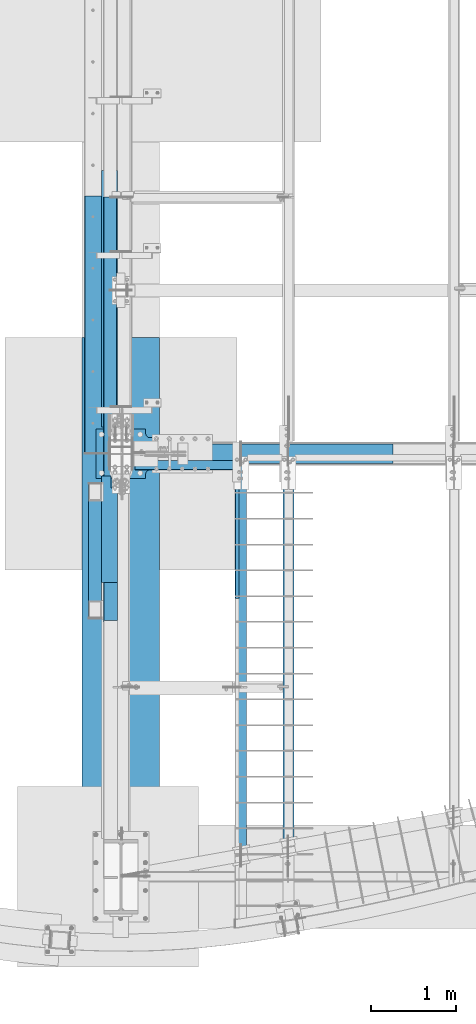
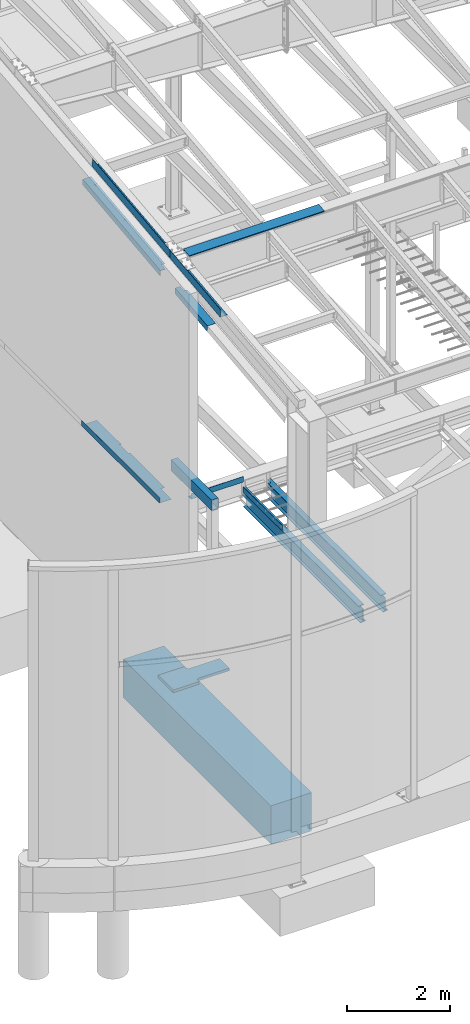
# One storey, part 702 of 1179: 13 beams, 10 elements without a shape of their own.
"""IFC2X3 building model written with IfcOpenShell, lengths in millimetres."""

from ifc_helpers import new_model, si_unit, frame, origin_with_axes, place, context, subcontext, project, spatial, faceted_brep, material, type_object, element, aggregate, save


model = new_model("IFC2X3")

# Units and contexts
model_context = context("Model", 3, precision=1e-05, world=origin_with_axes())
body_context = subcontext(model_context, "Body", "Model", "MODEL_VIEW")
ifc_project = project(units=[si_unit("LENGTHUNIT", "METRE", prefix="MILLI"), si_unit("AREAUNIT", "SQUARE_METRE"), si_unit("VOLUMEUNIT", "CUBIC_METRE"), si_unit("MASSUNIT", "GRAM", prefix="KILO"), si_unit("TIMEUNIT", "SECOND"), si_unit("PLANEANGLEUNIT", "RADIAN"), si_unit("SOLIDANGLEUNIT", "STERADIAN"), si_unit("THERMODYNAMICTEMPERATUREUNIT", "DEGREE_CELSIUS"), si_unit("LUMINOUSINTENSITYUNIT", "LUMEN")], contexts=[model_context])

# Site, building, storey
site_placement = place(None, origin_with_axes())
site = spatial("IfcSite", under=ifc_project, at=site_placement, CompositionType="ELEMENT")
building_placement = place(site_placement, origin_with_axes())
building = spatial("IfcBuilding", under=site, at=building_placement, Name="Undefined", CompositionType="ELEMENT")
storey_placement = place(building_placement, origin_with_axes())
storey = spatial("IfcBuildingStorey", under=building, at=storey_placement, Name="Undefined", CompositionType="ELEMENT", Elevation=0.0)

# Assembly, beam
assembly_1_placement = place(storey_placement, origin_with_axes())
assembly_1 = element("IfcElementAssembly", 1, at=assembly_1_placement, inside=storey, Name="BEAM", AssemblyPlace="NOTDEFINED", PredefinedType="RIGID_FRAME")
ifc_material_1 = material(Name="STEEL/A36")
beam_type_1 = type_object("IfcBeamType", PredefinedType="NOTDEFINED")
beam_1_placement = place(assembly_1_placement, frame((1828.8, 4498.09374519487, 3851.275), z_axis=(0.0, -1.0, 0.0), x_axis=(-1.0, 0.0, 0.0)))
beam_1 = element("IfcBeam", 2, at=beam_1_placement, type_object=beam_type_1, material=ifc_material_1, Name="BENT_PLATE", context=body_context, shape_type="Brep", body=[
    faceted_brep([(0.0, -3.17500000000018, -770.731), (0.0, -3.17500000000018, 770.731), (0.0, 3.17500000000018, 770.731), (0.0, 3.17500000000018, -770.731), (50.7999992370603, 3.17500000000018, 770.731), (50.7999992370603, 3.17500000000018, -770.731), (44.4499992370604, -3.17500000000018, -770.731), (44.4499992370604, -3.17500000000018, 770.731), (50.7999992370603, -130.175006103515, 770.731), (50.7999992370603, -130.175006103515, -770.731), (44.4499992370604, -130.175006103515, 770.731), (44.4499992370604, -130.175006103515, -770.731)], [[[0, 1, 2, 3]], [[3, 2, 4, 5]], [[1, 0, 6, 7]], [[5, 4, 8, 9]], [[4, 2, 1, 7, 10, 8]], [[7, 6, 11, 10]], [[6, 0, 3, 5, 9, 11]], [[10, 11, 9, 8]]]),
])

assembly_2_placement = place(storey_placement, origin_with_axes())
assembly_2 = element("IfcElementAssembly", 3, at=assembly_2_placement, inside=storey, Name="BEAM", AssemblyPlace="NOTDEFINED", PredefinedType="RIGID_FRAME")
beam_type_2 = type_object("IfcBeamType", PredefinedType="NOTDEFINED")
beam_2_placement = place(assembly_2_placement, frame((1189.0375, 5357.81249923706, 4105.275), z_axis=(1.0, 0.0, 0.0), x_axis=(0.0, -1.0, 0.0)))
beam_2 = element("IfcBeam", 4, at=beam_2_placement, type_object=beam_type_2, material=ifc_material_1, Name="BENT_PLATE", context=body_context, shape_type="Brep", body=[
    faceted_brep([(0.0, -3.17500000000018, -588.9625), (0.0, -3.17500000000018, 588.9625), (0.0, 3.17500000000018, 588.9625), (0.0, 3.17500000000018, -588.9625), (115.88749923706, 3.17500000000018, 588.9625), (115.88749923706, 3.17500000000018, -588.9625), (109.53749923706, -3.17500000000018, -588.9625), (109.53749923706, -3.17500000000018, 588.9625), (115.88749923706, -130.175006103515, 588.9625), (115.88749923706, -130.175006103515, -588.9625), (109.53749923706, -130.175006103515, 588.9625), (109.53749923706, -130.175006103515, -588.9625)], [[[0, 1, 2, 3]], [[3, 2, 4, 5]], [[1, 0, 6, 7]], [[5, 4, 8, 9]], [[4, 2, 1, 7, 10, 8]], [[7, 6, 11, 10]], [[6, 0, 3, 5, 9, 11]], [[10, 11, 9, 8]]]),
])
aggregate(assembly_2, [beam_2])

assembly_3_placement = place(storey_placement, origin_with_axes())
assembly_3 = element("IfcElementAssembly", 5, at=assembly_3_placement, inside=storey, Name="BEAM", AssemblyPlace="NOTDEFINED", PredefinedType="RIGID_FRAME")
beam_type_3 = type_object("IfcBeamType", PredefinedType="NOTDEFINED")
beam_3_placement = place(assembly_3_placement, frame((388.937000073627, 4449.2773789716, 9752.83965328135), z_axis=(0.0, -0.993676357192036, -0.112282221021698), x_axis=(-1.0, 0.0, 0.0)))
beam_3 = element("IfcBeam", 6, at=beam_3_placement, type_object=beam_type_3, material=ifc_material_1, Name="BENT_PLATE", context=body_context, shape_type="Brep", body=[
    faceted_brep([(0.0, -3.17499999999927, 989.0125), (0.0, 3.17499999999927, 989.0125), (7.59428075980395e-10, 3.17499999995016, -512.621622757905), (7.59428075980395e-10, -3.17500000004293, -512.621622747168), (160.336999993557, 3.17500000008658, 989.01250000048), (153.986999993557, -3.17499999991014, 989.012500000472), (153.98699999479, -187.324999994375, 989.01250000074), (160.33699999479, -187.324999994376, 989.012500000749), (153.986999998946, -3.1750000000884, -989.012500000016), (153.986999997713, -187.324999997027, -989.012499999749), (160.336999997713, -187.324999997025, -989.012499999738), (160.336999998946, 3.17499999990832, -989.012500000009), (71.4369970332323, 3.17499999990832, -989.01250000014), (71.4369970332323, 3.18271074463519, -512.621622757906), (71.4369970332323, -3.1672892439783, -512.621622747169), (71.4369970332323, -3.1750000000884, -989.012500000138)], [[[0, 1, 2, 3]], [[4, 1, 0, 5, 6, 7]], [[5, 8, 9, 6]], [[6, 9, 10, 7]], [[11, 4, 7, 10]], [[1, 4, 11, 12, 13, 2]], [[3, 2, 13, 14]], [[8, 5, 0, 3, 14, 15]], [[11, 10, 9, 8, 15, 12]], [[14, 13, 12, 15]]]),
])

assembly_4_placement = place(storey_placement, origin_with_axes())
assembly_4 = element("IfcElementAssembly", 7, at=assembly_4_placement, inside=storey, Name="BEAM", AssemblyPlace="NOTDEFINED", PredefinedType="RIGID_FRAME")
beam_type_4 = type_object("IfcBeamType", PredefinedType="NOTDEFINED")
beam_4_placement = place(assembly_4_placement, frame((382.587000094216, 6952.81861077423, 10035.7346148309), z_axis=(0.0, -0.993676146336441, -0.112284087038017), x_axis=(-1.0, 0.0, 0.0)))
beam_4 = element("IfcBeam", 8, at=beam_4_placement, type_object=beam_type_4, material=ifc_material_1, Name="BENT_PLATE", context=body_context, shape_type="Brep", body=[
    faceted_brep([(65.0867358780383, -3.17500000056134, 1108.22581732511), (65.0867699073289, 3.14051142695462, 1108.22529517667), (4.5446313379216e-10, 3.17499999943539, 1108.22531653084), (4.5446313379216e-10, -3.17500000056134, 1108.22583870826), (65.0868503059941, -3.1749998297928, 1524.00206803444), (65.0868845205044, 3.17499999922256, 1524.00000000049), (147.637000022519, -3.1749999992262, -1524.00000000058), (0.0, -3.17499999999927, -1524.0), (0.0, 3.17499999999927, -1524.0), (153.987000022519, 3.17500000077052, -1524.00000000059), (153.987000000008, -187.324999998866, -1523.99999999923), (147.637000022954, -187.324999983153, -1524.00000000055), (153.987000024775, 3.17499999922438, 1524.00000000046), (153.987000000008, -187.325000000099, 1523.99999999907), (147.63700002434, -187.32499998574, 1524.00000000049), (147.637000024775, -3.17500000077416, 1524.00000000046)], [[[0, 1, 2, 3]], [[4, 5, 1, 0]], [[6, 7, 8, 9, 10, 11]], [[9, 12, 13, 10]], [[14, 11, 10, 13]], [[15, 6, 11, 14]], [[3, 7, 6, 15, 4, 0]], [[8, 7, 3, 2]], [[12, 9, 8, 2, 1, 5]], [[15, 14, 13, 12, 5, 4]]]),
])

# Beam
beam_type_5 = type_object("IfcBeamType", PredefinedType="NOTDEFINED")
beam_5_placement = place(assembly_3_placement, frame((388.93700004407, 4546.69980596482, 9235.04853559745), z_axis=(0.0, -0.993676146336441, -0.112284087038017), x_axis=(-1.0, 0.0, 0.0)))
beam_5 = element("IfcBeam", 9, at=beam_5_placement, type_object=beam_type_5, material=ifc_material_1, Name="BENT_PLATE", context=body_context, shape_type="Brep", body=[
    faceted_brep([(76.1995000434802, -3.17449425609811, -486.569000016836), (76.1995000434802, 3.1761193576549, -486.569000019329), (76.1995000434802, 3.174999999801, -632.619000000216), (76.1995000434802, -3.17500000019572, -632.619000000212), (5.05906427861191e-12, -3.17499999975189, -486.569000016836), (4.8260062612826e-11, 3.17500000024484, -486.56900001933), (179.387000042202, 3.17499999845677, 632.619000000224), (-1.30739863379858e-11, 3.17499999967731, 632.619000000215), (-5.62749846721999e-11, -3.17500000032123, 632.619000000218), (185.737000042202, -3.17500000158361, 632.619000000228), (185.737000042284, 136.524999949153, 632.619000000169), (179.387000042284, 136.524999949153, 632.619000000169), (179.387000042364, 3.17499999909887, -632.61900000021), (179.387000042284, 136.524999949903, -632.619000000266), (185.737000042284, 136.524999949903, -632.619000000266), (185.737000042364, -3.17500000094151, -632.619000000206)], [[[0, 1, 2, 3]], [[4, 5, 1, 0]], [[6, 7, 8, 9, 10, 11]], [[12, 6, 11, 13]], [[10, 14, 13, 11]], [[9, 15, 14, 10]], [[12, 13, 14, 15, 3, 2]], [[7, 6, 12, 2, 1, 5]], [[8, 7, 5, 4]], [[15, 9, 8, 4, 0, 3]]]),
])

aggregate(assembly_3, [beam_5, beam_3])

beam_6_placement = place(assembly_4_placement, frame((388.937000180325, 7265.79138675246, 9542.29352802201), z_axis=(0.0, -0.993676146336441, -0.112284087038017), x_axis=(-1.0, 0.0, 0.0)))
beam_6 = element("IfcBeam", 10, at=beam_6_placement, type_object=beam_type_5, material=ifc_material_1, Name="BENT_PLATE", context=body_context, shape_type="Brep", body=[
    faceted_brep([(62.7057501802541, -3.17512107995026, -1277.28529743479), (62.7057501802541, 3.17499920827322, -1277.28529743479), (-1.5194245861494e-09, 3.17500000064319, -1277.2852974348), (-1.62395963343442e-09, -3.17499999935353, -1277.28529743479), (62.7057501802498, -3.17512174280273, -1258.23529743503), (62.7057501802498, 3.17499935475644, -1258.23529743503), (-1.60054014486377e-09, -3.17499999936445, -1258.23529743503), (-1.49600509757875e-09, 3.1750000006341, -1258.23529743503), (185.737000203274, -3.17500000222026, 1523.9999999998), (185.737000201926, -3.17500000083055, -1523.99999999987), (185.737000202255, 136.524999793486, -1523.99999999991), (185.737000202948, 136.524999792873, 1523.99999999976), (76.1995001803246, -3.1756136138174, -108.485506398396), (76.1995001803246, 3.17500000000473, -108.485506398412), (-8.12292455520947e-11, 3.17500000005202, -108.485506398412), (-1.85764292837121e-10, -3.17499999994652, -108.485506398396), (76.1995001803246, -3.17561361384105, -92.6105063985433), (76.1995001803246, 3.17499999997744, -92.6105063985342), (-1.66210156749003e-10, -3.1749999999538, -92.6105063985433), (-6.16751094639767e-11, 3.17500000004475, -92.6105063985342), (7.27595761418343e-12, -3.1749999994372, 1377.94999996142), (7.27595761418343e-12, 3.17500000055588, 1377.94999996396), (76.1995001797359, -3.17550574784764, 1377.95000001703), (76.1995001797359, 3.17510786590537, 1377.95000001449), (76.1995001797359, -3.1750000051652, 1524.00000000082), (76.1995002269396, 3.17500000061045, 1523.99999999914), (179.387000202948, 136.524999792875, 1523.99999999976), (179.387000203274, 3.1749999978274, 1523.9999999998), (179.387000201926, 3.17499999921893, -1523.99999999987), (179.387000202255, 136.524999793486, -1523.99999999991), (0.0, -3.17499999999927, -1524.0), (0.0, 3.17499999999927, -1524.0)], [[[0, 1, 2, 3]], [[4, 5, 1, 0]], [[6, 7, 5, 4]], [[8, 9, 10, 11]], [[12, 13, 14, 15]], [[16, 17, 13, 12]], [[18, 19, 17, 16]], [[19, 18, 20, 21]], [[22, 23, 21, 20]], [[24, 25, 23, 22]], [[8, 11, 26, 27, 25, 24]], [[28, 27, 26, 29]], [[11, 10, 29, 26]], [[9, 30, 31, 28, 29, 10]], [[31, 30, 3, 2]], [[14, 13, 17, 19, 21, 23, 25, 27, 28, 31, 2, 1, 5, 7]], [[15, 14, 7, 6]], [[3, 30, 9, 8, 24, 22, 20, 18, 16, 12, 15, 6, 4, 0]]]),
])

aggregate(assembly_4, [beam_4, beam_6])

# Assembly, beam
assembly_5_placement = place(storey_placement, origin_with_axes())
assembly_5 = element("IfcElementAssembly", 11, at=assembly_5_placement, inside=storey, Name="BEAM", AssemblyPlace="NOTDEFINED", PredefinedType="RIGID_FRAME")
beam_type_6 = type_object("IfcBeamType", PredefinedType="NOTDEFINED")
beam_7_placement = place(assembly_5_placement, frame((2124.07499932981, 5543.55933465737, 9826.91628422066), z_axis=(-1.0, 0.0, 0.0), x_axis=(0.0, 0.0, 1.0)))
beam_7 = element("IfcBeam", 12, at=beam_7_placement, type_object=beam_type_6, material=ifc_material_1, Name="BENT_PLATE", context=body_context, shape_type="Brep", body=[
    faceted_brep([(-2.91038304567337e-11, -4.76250000000073, -1524.0), (-2.91038304567337e-11, -4.76250000000073, 1524.0), (2.91038304567337e-11, 4.76250000000073, 1524.0), (2.91038304567337e-11, 4.76250000000073, -1524.0), (46.9151566473611, 4.76249999974698, 1524.0), (46.9151566473611, 4.76249999974698, -1524.0), (36.2535598523627, -4.76250000019536, -1524.0), (36.2535598523627, -4.76250000019536, 1524.0), (21.449529282756, -220.662499999238, 1524.0), (21.449529282756, -220.662499999238, -1524.0), (12.939957335464, -211.13749999934, -1524.0), (12.939957335464, -211.13749999934, 1524.0), (1.17463059723377e-07, -220.662499999494, 1524.0), (1.17463059723377e-07, -220.662499999494, -1524.0), (1.17350282380357e-07, -211.137499999494, 1524.0), (1.17350282380357e-07, -211.137499999494, -1524.0)], [[[0, 1, 2, 3]], [[3, 2, 4, 5]], [[1, 0, 6, 7]], [[5, 4, 8, 9]], [[7, 6, 10, 11]], [[9, 8, 12, 13]], [[8, 4, 2, 1, 7, 11, 14, 12]], [[11, 10, 15, 14]], [[10, 6, 0, 3, 5, 9, 13, 15]], [[14, 15, 13, 12]]]),
])
aggregate(assembly_5, [beam_7])

assembly_6_placement = place(storey_placement, origin_with_axes())
assembly_6 = element("IfcElementAssembly", 13, at=assembly_6_placement, inside=storey, Name="BEAM", AssemblyPlace="NOTDEFINED", PredefinedType="RIGID_FRAME")
beam_type_7 = type_object("IfcBeamType", PredefinedType="NOTDEFINED")
beam_8_placement = place(assembly_6_placement, frame((352.425000000002, 6959.60000275072, 4105.275), z_axis=(0.0, -1.0, 0.0), x_axis=(-1.0, 0.0, 0.0)))
beam_8 = element("IfcBeam", 14, at=beam_8_placement, type_object=beam_type_7, material=ifc_material_1, Name="BENT_PLATE", context=body_context, shape_type="Brep", body=[
    faceted_brep([(34.3802070617676, -3.17500000000018, -577.850009456311), (34.3802070617676, 3.17500000000018, -577.850009456311), (0.0, 3.17500000000018, -577.850009456311), (0.0, -3.17500000000018, -577.850009456311), (34.3802070617676, -3.17500000000018, -234.949985042248), (34.3802070617676, 3.17500000000018, -234.949985042248), (0.0, -3.17500000000018, -234.949985042248), (0.0, 3.17500000000018, -234.949985042248), (346.074987792969, -3.17500000000109, 1524.0), (346.074987792969, -3.17500000000109, -1524.0), (346.074987792969, -130.175006103515, -1524.0), (346.074987792969, -130.175006103515, 1524.0), (82.5500012419194, -3.17500000000018, 1118.38340489881), (82.5500012419194, 3.17500000000018, 1118.38340489881), (0.0, 3.17500000000018, 1118.39121561485), (0.0, -3.17500000000018, 1118.39121561485), (82.5499996747923, -3.17500000000018, 1523.99220149009), (82.5499996747923, 3.17500000000018, 1524.0), (352.424987792969, -130.175006103515, 1524.0), (352.424987792969, 3.17499999999927, 1524.0), (352.424987792969, 3.17499999999927, -1524.0), (352.424987792969, -130.175006103515, -1524.0), (0.0, -3.17499999999927, -1524.0), (0.0, 3.17499999999927, -1524.0)], [[[0, 1, 2, 3]], [[4, 5, 1, 0]], [[6, 7, 5, 4]], [[8, 9, 10, 11]], [[12, 13, 14, 15]], [[16, 17, 13, 12]], [[8, 11, 18, 19, 17, 16]], [[20, 19, 18, 21]], [[11, 10, 21, 18]], [[9, 22, 23, 20, 21, 10]], [[23, 22, 3, 2]], [[14, 13, 17, 19, 20, 23, 2, 1, 5, 7]], [[15, 14, 7, 6]], [[3, 22, 9, 8, 16, 12, 15, 6, 4, 0]]]),
])
aggregate(assembly_6, [beam_8])

# Beam
ifc_material_2 = material(Name="STEEL/A992")
beam_type_8 = type_object("IfcBeamType", Name="W14X26", PredefinedType="NOTDEFINED")
beam_9_placement = place(assembly_1_placement, frame((1854.2, 691.312577762722, 3671.8875), z_axis=(0.0, 0.0, 1.0), x_axis=(0.0, 1.0, 0.0)))
beam_9 = element("IfcBeam", 15, at=beam_9_placement, type_object=beam_type_8, material=ifc_material_2, Name="BEAM", ObjectType="W14X26", context=body_context, shape_type="Brep", body=[
    faceted_brep([(4577.59992528904, -3.17499999999995, -165.1), (4577.59992528904, -63.5, -165.1), (4577.59992528904, -63.5, -176.2125), (4577.59992528904, 28.5749996185302, -176.2125), (4577.59992528904, 28.5749996185302, -165.1), (4577.59992528904, 3.17499999999995, -165.1), (4577.59992528904, 3.17499999999995, -33.3374996185316), (4577.59992528904, -3.17499999999995, -33.3374996185316), (4579.53338513421, 3.17499999999995, -23.6173405824406), (4579.53338513421, -3.17499999999995, -23.6173405824406), (4585.03941293517, 3.17499999999995, -15.3769876461333), (4585.03941293517, -3.17499999999995, -15.3769876461333), (4593.27976587148, 3.17499999999995, -9.87095984517691), (4593.27976587148, -3.17499999999995, -9.87095984517691), (4602.99992490757, 3.17499999999995, -7.93750000000136), (4602.99992490757, -3.17499999999995, -7.93750000000136), (4712.53742528904, -3.17499999999995, -7.93750000000136), (4712.53742223728, 3.17499999999995, -7.93750000000136), (4712.53742223728, -63.5, 165.1), (4712.53742223728, -63.5, 176.2125), (105.35615323098, -63.5, 176.2125), (98.8397136083431, -63.5, 165.1), (4712.53742223728, 3.17499999999995, 176.2125), (4712.53742223728, 3.17499999999995, 165.1), (4602.99992490757, 3.17499999999995, 165.1), (4602.99992490757, 3.17499999999995, 176.2125), (4593.27976587148, 5.10845984517573, 176.2125), (4585.03941293517, 10.6144876461317, 176.2125), (4579.53338513421, 18.854840582439, 176.2125), (4577.59992528904, 28.5749996185302, 176.2125), (4577.59992528904, 63.5, 176.2125), (82.7523516449764, 63.5, 176.2125), (76.23591202234, 63.5, 165.1), (4577.59992528904, 63.5, 165.1), (4577.59992528904, 28.5749996185302, 165.1), (4579.53338513421, 18.854840582439, 165.1), (4585.03941293517, 10.6144876461317, 165.1), (4593.27976587148, 5.10845984517573, 165.1), (86.9727177756913, 3.17499999999995, 165.1), (32.3299982146518, -63.5, -165.1), (21.5931924613005, -3.17499999999995, -165.1), (21.8259821526158, -3.17499999999995, -164.703000259399), (20.6957920733156, 3.17499999999995, -164.703000259399), (20.463002382, 3.17499999999995, -165.1), (9.72619662864872, 63.5, -165.1), (3.21013331628819, 63.5, -176.2125), (25.8139349022913, -63.5, -176.2125), (38.1832580331089, -3.17499999999995, -164.703000259399), (37.0530679538094, 3.17499999999995, -164.703000259399), (54.7689134870706, -3.17499999999995, -158.045004848507), (53.6387234077712, 3.17499999999995, -158.045004848507), (58.9178459884611, -3.17499999999995, -154.857742002601), (57.7876559091617, 3.17499999999995, -154.857742002601), (60.7584206939351, -3.17499999999995, -150.003873155929), (59.6282306146358, 3.17499999999995, -150.003873155929), (59.7460515670933, -3.17499999999995, -144.919552564306), (58.6158614877939, 3.17499999999995, -144.919552564306), (56.1802766209923, -3.17499999999995, -141.10912014425), (55.0500865416928, 3.17499999999995, -141.10912014425), (51.1161311328278, -3.17499999999995, -139.7), (49.9859410535283, 3.17499999999995, -139.7), (18.3020261524669, -3.17499999999995, -139.7), (17.1718360731667, 3.17499999999995, -139.7), (18.3020261524669, -3.17499999999995, 139.7), (17.1718360731667, 3.17499999999995, 139.7), (123.376362989785, -3.17499999999995, 139.7), (122.246172910485, 3.17499999999995, 139.7), (128.440508477951, -3.17499999999995, 141.10912014425), (127.310318398651, 3.17499999999995, 141.10912014425), (132.006283424052, -3.17499999999995, 144.919552564306), (130.876093344752, 3.17499999999995, 144.919552564306), (133.018652550893, -3.17499999999995, 150.003873155928), (131.888462471594, 3.17499999999995, 150.003873155928), (131.178077845419, -3.17499999999995, 154.857742002601), (130.04788776612, 3.17499999999995, 154.857742002601), (127.029145344027, -3.17499999999995, 158.045004848507), (125.898955264728, 3.17499999999995, 158.045004848507), (110.443489890066, -3.17499999999995, 164.703000259399), (109.313299810766, 3.17499999999995, 164.703000259399), (87.8701047197993, -3.17499999999995, 164.703000259399), (86.739914640499, 3.17499999999995, 164.703000259399), (88.1029078549918, -3.17499999999995, 165.1), (4712.53742223728, -3.17499999999995, 165.1), (4577.59992528904, 63.5, -165.1), (4577.59992528904, 63.5, -176.2125)], [[[0, 1, 2, 3, 4, 5, 6, 7]], [[7, 6, 8, 9]], [[9, 8, 10, 11]], [[11, 10, 12, 13]], [[13, 12, 14, 15]], [[16, 15, 14, 17]], [[18, 19, 20, 21]], [[22, 23, 24, 25]], [[26, 27, 28, 29, 30, 31, 20, 19, 22, 25]], [[32, 31, 30, 33]], [[29, 34, 33, 30]], [[28, 35, 34, 29]], [[27, 36, 35, 28]], [[26, 37, 36, 27]], [[25, 24, 37, 26]], [[38, 32, 33, 34, 35, 36, 37, 24]], [[39, 40, 41, 42, 43, 44, 45, 46]], [[47, 48, 42, 41]], [[49, 50, 48, 47]], [[51, 52, 50, 49]], [[53, 54, 52, 51]], [[55, 56, 54, 53]], [[57, 58, 56, 55]], [[59, 60, 58, 57]], [[60, 59, 61, 62]], [[63, 64, 62, 61]], [[65, 66, 64, 63]], [[67, 68, 66, 65]], [[69, 70, 68, 67]], [[71, 72, 70, 69]], [[73, 74, 72, 71]], [[75, 76, 74, 73]], [[77, 78, 76, 75]], [[78, 77, 79, 80]], [[20, 31, 32, 38, 80, 79, 81, 21]], [[82, 18, 21, 81]], [[23, 22, 19, 18, 82, 16, 17]], [[12, 10, 8, 6, 5, 43, 42, 48, 50, 52, 54, 56, 58, 60, 62, 64, 66, 68, 70, 72, 74, 76, 78, 80, 38, 24, 23, 17, 14]], [[83, 44, 43, 5, 4]], [[45, 44, 83, 84]], [[4, 3, 84, 83]], [[46, 45, 84, 3, 2]], [[39, 46, 2, 1]], [[40, 39, 1, 0]], [[82, 81, 79, 77, 75, 73, 71, 69, 67, 65, 63, 61, 59, 57, 55, 53, 51, 49, 47, 41, 40, 0, 7, 9, 11, 13, 15, 16]]]),
])

aggregate(assembly_1, [beam_1, beam_9])

# Assembly, beam
assembly_7_placement = place(storey_placement, origin_with_axes())
assembly_7 = element("IfcElementAssembly", 16, at=assembly_7_placement, inside=storey, Name="BEAM", AssemblyPlace="NOTDEFINED", PredefinedType="RIGID_FRAME")
beam_10_placement = place(assembly_7_placement, frame((2413.0, 790.848288038665, 3671.8875), z_axis=(0.0, 0.0, 1.0), x_axis=(0.0, 1.0, 0.0)))
beam_10 = element("IfcBeam", 17, at=beam_10_placement, type_object=beam_type_8, material=ifc_material_2, Name="BEAM", ObjectType="W14X26", context=body_context, shape_type="Brep", body=[
    faceted_brep([(4478.06421501309, -3.17500000000018, -165.1), (4478.06421501309, -63.5, -165.1), (4478.06421501309, -63.5, -176.2125), (4478.06421501309, 28.5749996185305, -176.2125), (4478.06421501309, 28.5749996185305, -165.1), (4478.06421501309, 3.17500000000018, -165.1), (4478.06421501309, 3.17500000000018, -33.3374996185316), (4478.06421501309, -3.17500000000018, -33.3374996185316), (4479.99767485827, 3.17500000000018, -23.6173405824406), (4479.99767485827, -3.17500000000018, -23.6173405824406), (4485.50370265922, 3.17500000000018, -15.3769876461333), (4485.50370265922, -3.17500000000018, -15.3769876461333), (4493.74405559553, 3.17500000000018, -9.87095984517691), (4493.74405559553, -3.17500000000018, -9.87095984517691), (4503.46421463162, 3.17500000000018, -7.93750000000136), (4503.46421463162, -3.17500000000018, -7.93750000000136), (4613.00171501309, -3.17500000000018, -7.93750000000136), (4613.00171196133, 3.17500000000018, -7.93750000000136), (4613.00171196133, -63.5, 165.1), (4613.00171196133, -63.5, 176.2125), (105.277169933423, -63.5, 176.2125), (98.7607303107852, -63.5, 165.1), (4613.00171196133, 3.17500000000018, 176.2125), (4613.00171196133, 3.17500000000018, 165.1), (4503.46421463162, 3.17500000000018, 165.1), (4503.46421463162, 3.17500000000018, 176.2125), (4493.74405559553, 5.10845984517573, 176.2125), (4485.50370265922, 10.6144876461321, 176.2125), (4479.99767485827, 18.8548405824395, 176.2125), (4478.06421501309, 28.5749996185305, 176.2125), (4478.06421501309, 63.5, 176.2125), (82.6733683474195, 63.5, 176.2125), (76.1569287247821, 63.5, 165.1), (4478.06421501309, 63.5, 165.1), (4478.06421501309, 28.5749996185305, 165.1), (4479.99767485827, 18.8548405824395, 165.1), (4485.50370265922, 10.6144876461321, 165.1), (4493.74405559553, 5.10845984517573, 165.1), (86.8937344781334, 3.17500000000018, 165.1), (32.2510149170866, -63.5, -165.1), (21.5142091637344, -3.17500000000018, -165.1), (21.7469988550504, -3.17500000000018, -164.703000259399), (20.6168087757502, 3.17500000000018, -164.703000259399), (20.3840190844348, 3.17500000000018, -165.1), (9.64721333108264, 63.5, -165.1), (3.13115001872211, 63.5, -176.2125), (25.7349516047252, -63.5, -176.2125), (38.1042747355195, -3.17500000000018, -164.703000259399), (36.9740846562198, 3.17500000000018, -164.703000259399), (54.6899301894814, -3.17500000000018, -158.045004848507), (53.5597401101817, 3.17500000000018, -158.045004848507), (58.8388626908719, -3.17500000000018, -154.857742002601), (57.7086726115722, 3.17500000000018, -154.857742002601), (60.679437396346, -3.17500000000018, -150.003873155929), (59.5492473170463, 3.17500000000018, -150.003873155929), (59.6670682695042, -3.17500000000018, -144.919552564306), (58.5368781902044, 3.17500000000018, -144.919552564306), (56.1012933234031, -3.17500000000018, -141.10912014425), (54.9711032441033, 3.17500000000018, -141.10912014425), (51.0371478352386, -3.17500000000018, -139.7), (49.9069577559388, 3.17500000000018, -139.7), (18.2230428549177, -3.17500000000018, -139.7), (17.0928527756175, 3.17500000000018, -139.7), (18.2230428549177, -3.17500000000018, 139.7), (17.0928527756175, 3.17500000000018, 139.7), (123.297379692225, -3.17500000000018, 139.7), (122.167189612925, 3.17500000000018, 139.7), (128.36152518039, -3.17500000000018, 141.10912014425), (127.231335101091, 3.17500000000018, 141.10912014425), (131.927300126491, -3.17500000000018, 144.919552564306), (130.797110047192, 3.17500000000018, 144.919552564306), (132.939669253333, -3.17500000000018, 150.003873155928), (131.809479174034, 3.17500000000018, 150.003873155928), (131.099094547859, -3.17500000000018, 154.857742002601), (129.968904468559, 3.17500000000018, 154.857742002601), (126.950162046467, -3.17500000000018, 158.045004848507), (125.819971967168, 3.17500000000018, 158.045004848507), (110.364506592505, -3.17500000000018, 164.703000259399), (109.234316513206, 3.17500000000018, 164.703000259399), (87.7911214222411, -3.17500000000018, 164.703000259399), (86.6609313429409, 3.17500000000018, 164.703000259399), (88.0239245574339, -3.17500000000018, 165.1), (4613.00171196133, -3.17500000000018, 165.1), (4478.06421501309, 63.5, -165.1), (4478.06421501309, 63.5, -176.2125)], [[[0, 1, 2, 3, 4, 5, 6, 7]], [[7, 6, 8, 9]], [[9, 8, 10, 11]], [[11, 10, 12, 13]], [[13, 12, 14, 15]], [[16, 15, 14, 17]], [[18, 19, 20, 21]], [[22, 23, 24, 25]], [[26, 27, 28, 29, 30, 31, 20, 19, 22, 25]], [[32, 31, 30, 33]], [[29, 34, 33, 30]], [[28, 35, 34, 29]], [[27, 36, 35, 28]], [[26, 37, 36, 27]], [[25, 24, 37, 26]], [[38, 32, 33, 34, 35, 36, 37, 24]], [[39, 40, 41, 42, 43, 44, 45, 46]], [[47, 48, 42, 41]], [[49, 50, 48, 47]], [[51, 52, 50, 49]], [[53, 54, 52, 51]], [[55, 56, 54, 53]], [[57, 58, 56, 55]], [[59, 60, 58, 57]], [[60, 59, 61, 62]], [[63, 64, 62, 61]], [[65, 66, 64, 63]], [[67, 68, 66, 65]], [[69, 70, 68, 67]], [[71, 72, 70, 69]], [[73, 74, 72, 71]], [[75, 76, 74, 73]], [[77, 78, 76, 75]], [[78, 77, 79, 80]], [[20, 31, 32, 38, 80, 79, 81, 21]], [[82, 18, 21, 81]], [[23, 22, 19, 18, 82, 16, 17]], [[12, 10, 8, 6, 5, 43, 42, 48, 50, 52, 54, 56, 58, 60, 62, 64, 66, 68, 70, 72, 74, 76, 78, 80, 38, 24, 23, 17, 14]], [[83, 44, 43, 5, 4]], [[45, 44, 83, 84]], [[4, 3, 84, 83]], [[46, 45, 84, 3, 2]], [[39, 46, 2, 1]], [[40, 39, 1, 0]], [[82, 81, 79, 77, 75, 73, 71, 69, 67, 65, 63, 61, 59, 57, 55, 53, 51, 49, 47, 41, 40, 0, 7, 9, 11, 13, 15, 16]]]),
])
aggregate(assembly_7, [beam_10])

assembly_8_placement = place(storey_placement, origin_with_axes())
assembly_8 = element("IfcElementAssembly", 18, at=assembly_8_placement, inside=storey, Name="BEAM", AssemblyPlace="NOTDEFINED", PredefinedType="RIGID_FRAME")
ifc_material_3 = material()
beam_type_9 = type_object("IfcBeamType", Name="HSS10X6X3/8", PredefinedType="NOTDEFINED")
beam_11_placement = place(assembly_8_placement, frame((127.0, 3489.325, 5207.0), z_axis=(0.0, 0.0, 1.0), x_axis=(0.0, 1.0, 0.0)))
beam_11 = element("IfcBeam", 19, at=beam_11_placement, type_object=beam_type_9, material=ifc_material_3, Name="BEAM", ObjectType="HSS10X6X3/8", context=body_context, shape_type="Brep", body=[
    faceted_brep([(6.34999999999991, 66.675, -117.475), (6.34999999999991, -66.675, -117.475), (1593.85, -66.675, -117.475), (1593.85, 66.675, -117.475), (6.34999999999991, -66.675, 117.475), (1593.85, -66.675, 117.475), (6.34999999999991, 66.675, 117.475), (1593.85, 66.675, 117.475), (6.34999999999991, 76.2, -127.0), (6.34999999999991, 76.2, 127.0), (1593.85, 76.2, 127.0), (1593.85, 76.2, -127.0), (6.34999999999991, -76.2, 127.0), (1593.85, -76.2, 127.0), (6.34999999999991, -76.2, -127.0), (1593.85, -76.2, -127.0)], [[[0, 1, 2, 3]], [[1, 4, 5, 2]], [[4, 6, 7, 5]], [[6, 0, 3, 7]], [[8, 9, 10, 11]], [[9, 12, 13, 10]], [[12, 14, 15, 13]], [[14, 8, 11, 15]], [[13, 15, 11, 10], [5, 7, 3, 2]], [[14, 12, 9, 8], [6, 4, 1, 0]]]),
])
aggregate(assembly_8, [beam_11])

assembly_9_placement = place(storey_placement, origin_with_axes())
assembly_9 = element("IfcElementAssembly", 20, at=assembly_9_placement, inside=storey, Name="GRADE_BEAM", AssemblyPlace="NOTDEFINED", PredefinedType="REINFORCEMENT_UNIT")
ifc_material_4 = material(Name="CONCRETE/5000")
beam_type_10 = type_object("IfcBeamType", PredefinedType="NOTDEFINED")
beam_12_placement = place(assembly_9_placement, frame((431.800061035268, 1047.75000502925, -889.0), z_axis=(0.0, 0.0, 1.0), x_axis=(0.0, 1.0, 0.0)))
beam_12 = element("IfcBeam", 21, at=beam_12_placement, type_object=beam_type_10, material=ifc_material_4, Name="GRADE_BEAM", context=body_context, shape_type="Brep", body=[
    faceted_brep([(4.84305928694084e-11, 457.2, -457.2), (4.84305928694084e-11, 457.2, 457.2), (5759.4499949708, 457.200000000046, 457.2), (5759.4499949708, 457.200000000046, -457.2), (-4.82032191939652e-11, -457.2, 457.2), (5759.4499949707, -457.199999999954, 457.2), (-4.82032191939652e-11, -457.2, -457.2), (5759.4499949707, -457.199999999954, -457.2)], [[[0, 1, 2, 3]], [[1, 4, 5, 2]], [[4, 6, 7, 5]], [[6, 0, 3, 7]], [[5, 7, 3, 2]], [[6, 4, 1, 0]]]),
])
aggregate(assembly_9, [beam_12])

assembly_10_placement = place(storey_placement, origin_with_axes())
assembly_10 = element("IfcElementAssembly", 22, at=assembly_10_placement, inside=storey, Name="COLUMN", AssemblyPlace="NOTDEFINED", PredefinedType="RIGID_FRAME")
ifc_material_5 = material(Name="STEEL/A572-GR.50")
beam_type_11 = type_object("IfcBeamType", PredefinedType="NOTDEFINED")
beam_13_placement = place(assembly_10_placement, frame((139.700503540043, 5435.6, -247.65), z_axis=(0.0, 1.0, 0.0), x_axis=(1.0, 0.0, 0.0)))
beam_13 = element("IfcBeam", 23, at=beam_13_placement, type_object=beam_type_11, material=ifc_material_5, context=body_context, shape_type="Brep", body=[
    faceted_brep([(584.199496459958, -31.75, 292.1), (584.199496459958, -31.75, 241.30000076336), (584.199496459958, 31.75, 241.30000076336), (584.199496459958, 31.75, 292.1), (588.066416150308, -31.75, 221.859682691178), (588.066416150308, 31.75, 221.859682691178), (599.078471752222, -31.75, 205.378976818563), (599.078471752222, 31.75, 205.378976818563), (615.559177624837, -31.75, 194.366921216651), (615.559177624837, 31.75, 194.366921216651), (634.999495697019, -31.75, 190.500001526299), (634.999495697019, 31.75, 190.500001526299), (1320.79949645996, -31.75, 190.500001526299), (1320.79949645996, 31.75, 190.500001526299), (0.0, -31.75, -292.1), (0.0, -31.75, 292.1), (0.0, 31.75, 292.1), (0.0, 31.75, -292.1), (584.199496459958, 31.75, -292.1), (584.199496459958, -31.75, -292.1), (584.199496459958, 31.75, -241.30000076336), (584.199496459958, -31.75, -241.30000076336), (588.066416150308, 31.75, -221.859682691178), (588.066416150308, -31.75, -221.859682691178), (599.078471752222, 31.75, -205.378976818563), (599.078471752222, -31.75, -205.378976818563), (615.559177624837, 31.75, -194.366921216651), (615.559177624837, -31.75, -194.366921216651), (634.999495697019, 31.75, -190.500001526299), (634.999495697019, -31.75, -190.500001526299), (1320.79949645996, -31.75, -190.500001526299), (1320.79949645996, 31.75, -190.500001526299)], [[[0, 1, 2, 3]], [[4, 5, 2, 1]], [[6, 7, 5, 4]], [[8, 9, 7, 6]], [[10, 11, 9, 8]], [[12, 13, 11, 10]], [[14, 15, 16, 17]], [[14, 17, 18, 19]], [[19, 18, 20, 21]], [[21, 20, 22, 23]], [[23, 22, 24, 25]], [[25, 24, 26, 27]], [[27, 26, 28, 29]], [[30, 29, 28, 31]], [[8, 6, 4, 1, 0, 15, 14, 19, 21, 23, 25, 27, 29, 30, 12, 10]], [[16, 15, 0, 3]], [[31, 28, 26, 24, 22, 20, 18, 17, 16, 3, 2, 5, 7, 9, 11, 13]], [[30, 31, 13, 12]]]),
])
aggregate(assembly_10, [beam_13])

save(model, "model.ifc")
